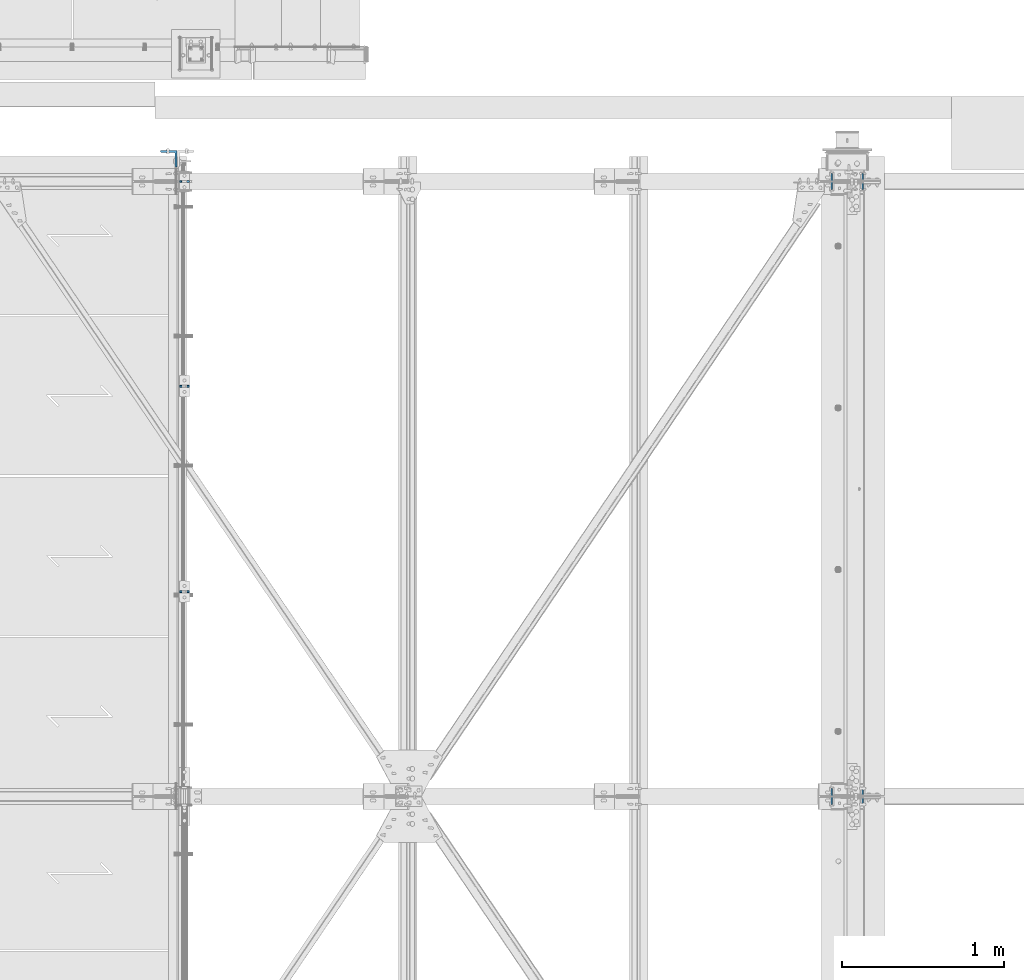
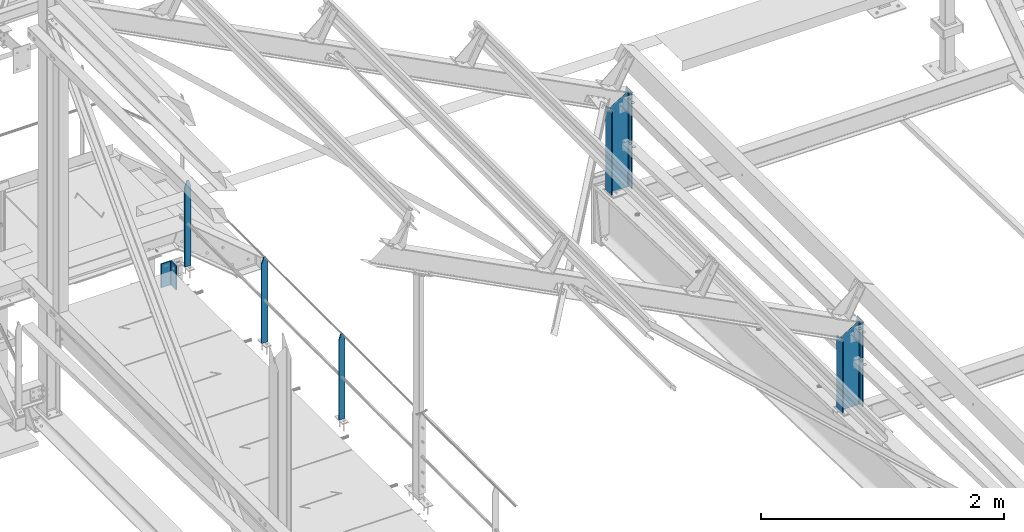
# One storey, part 33 of 496: 6 columns, 4 elements without a shape of their own.
"""IFC2X3 building model written with IfcOpenShell, lengths in millimetres."""

from ifc_helpers import new_model, si_unit, frame, origin_with_axes, origin_2d_with_axis, place, context, subcontext, project, spatial, rectangle, i_section, l_section, extrude, clip, halfspace, material, type_object, element, aggregate, save


model = new_model("IFC2X3")

# Units and contexts
model_context = context("Model", 3, precision=1e-05, world=origin_with_axes())
body_context = subcontext(model_context, "Body", "Model", "MODEL_VIEW")
ifc_project = project(units=[si_unit("LENGTHUNIT", "METRE", prefix="MILLI"), si_unit("AREAUNIT", "SQUARE_METRE"), si_unit("VOLUMEUNIT", "CUBIC_METRE"), si_unit("MASSUNIT", "GRAM", prefix="KILO"), si_unit("TIMEUNIT", "SECOND"), si_unit("PLANEANGLEUNIT", "RADIAN"), si_unit("SOLIDANGLEUNIT", "STERADIAN"), si_unit("THERMODYNAMICTEMPERATUREUNIT", "DEGREE_CELSIUS"), si_unit("LUMINOUSINTENSITYUNIT", "LUMEN")], contexts=[model_context])

# Site, building, storey
site_placement = place(None, origin_with_axes())
site = spatial("IfcSite", under=ifc_project, at=site_placement, CompositionType="ELEMENT")
building_placement = place(site_placement, origin_with_axes())
building = spatial("IfcBuilding", under=site, at=building_placement, Name="Undefined", CompositionType="ELEMENT")
storey_placement = place(building_placement, origin_with_axes())
storey = spatial("IfcBuildingStorey", under=building, at=storey_placement, Name="Undefined", CompositionType="ELEMENT", Elevation=0.0)

# Assembly, columns
assembly_1_placement = place(storey_placement, origin_with_axes())
assembly_1 = element("IfcElementAssembly", 1, at=assembly_1_placement, inside=storey, Name="MAIN COURANTE", AssemblyPlace="NOTDEFINED", PredefinedType="NOTDEFINED")
ifc_material_1 = material(Name="Undefined/S235-E24")
column_type_1 = type_object("IfcColumnType", PredefinedType="NOTDEFINED")
column_1_placement = place(assembly_1_placement, frame((24783.9916087498, 15200.0000000319, 8249.99999828624), z_axis=(0.0, 0.0, 1.0), x_axis=(1.0, 0.0, 0.0)))
column_1 = element("IfcColumn", 2, at=column_1_placement, type_object=column_type_1, material=ifc_material_1, Name="MONTANT", context=body_context, shape_type="Clipping", body=[
    clip(clip(extrude(rectangle(XDim=10.0, YDim=60.0, at=origin_2d_with_axis()), frame((0.0, 0.0, 857.599997130677), z_axis=(0.0, 0.0, -1.0), x_axis=(0.0, 1.0, 0.0)), (0.0, 0.0, 1.0), 857.6), halfspace(frame((30.0000001657245, -5.000000004674, 797.599997170884), z_axis=(0.948683298050514, 0.0, 0.316227766016838), x_axis=(-0.316227766016838, 0.0, 0.948683298050514)), False)), halfspace(frame((-29.9999998342682, 4.99999999524351, 797.599997177174), z_axis=(-0.948683298050514, 0.0, 0.316227766016838), x_axis=(0.316227766016838, 0.0, 0.948683298050514)), False)),
])
column_2_placement = place(assembly_1_placement, frame((24783.9916067239, 12665.0034395729, 8250.00000011812), z_axis=(0.0, 0.0, 1.0), x_axis=(1.0, 0.0, 0.0)))
column_2 = element("IfcColumn", 3, at=column_2_placement, type_object=column_type_1, material=ifc_material_1, Name="MONTANT", context=body_context, shape_type="Clipping", body=[
    clip(clip(extrude(rectangle(XDim=10.0, YDim=60.0, at=origin_2d_with_axis()), frame((0.0, 0.0, 857.599997130677), z_axis=(0.0, 0.0, -1.0), x_axis=(0.0, 1.0, 0.0)), (0.0, 0.0, 1.0), 857.6), halfspace(frame((30.0000001657245, -5.000000004674, 797.599997170884), z_axis=(0.948683298050514, 0.0, 0.316227766016838), x_axis=(-0.316227766016838, 0.0, 0.948683298050514)), False)), halfspace(frame((-29.9999998342682, 4.99999999524351, 797.599997177174), z_axis=(-0.948683298050514, 0.0, 0.316227766016838), x_axis=(0.316227766016838, 0.0, 0.948683298050514)), False)),
])
column_3_placement = place(assembly_1_placement, frame((24783.9916077785, 13935.0034395729, 8249.99999924743), z_axis=(0.0, 0.0, 1.0), x_axis=(1.0, 0.0, 0.0)))
column_3 = element("IfcColumn", 4, at=column_3_placement, type_object=column_type_1, material=ifc_material_1, Name="MONTANT", context=body_context, shape_type="Clipping", body=[
    clip(clip(extrude(rectangle(XDim=10.0, YDim=60.0, at=origin_2d_with_axis()), frame((0.0, 0.0, 857.599997130677), z_axis=(0.0, 0.0, -1.0), x_axis=(0.0, 1.0, 0.0)), (0.0, 0.0, 1.0), 857.6), halfspace(frame((30.0000001657245, -5.000000004674, 797.599997170884), z_axis=(0.948683298050514, 0.0, 0.316227766016838), x_axis=(-0.316227766016838, 0.0, 0.948683298050514)), False)), halfspace(frame((-29.9999998342682, 4.99999999524351, 797.599997177174), z_axis=(-0.948683298050514, 0.0, 0.316227766016838), x_axis=(0.316227766016838, 0.0, 0.948683298050514)), False)),
])
aggregate(assembly_1, [column_1, column_2, column_3])

# Assembly, column
assembly_2_placement = place(storey_placement, origin_with_axes())
assembly_2 = element("IfcElementAssembly", 5, at=assembly_2_placement, inside=storey, AssemblyPlace="NOTDEFINED", PredefinedType="NOTDEFINED")
column_type_2 = type_object("IfcColumnType", PredefinedType="NOTDEFINED")
column_4_placement = place(assembly_2_placement, frame((24686.491600645, 15339.9999999094, 7970.00437164953), z_axis=(0.0, 0.0, 1.0), x_axis=(-1.0, 0.0, 0.0)))
column_4 = element("IfcColumn", 6, at=column_4_placement, type_object=column_type_2, material=ifc_material_1, context=body_context, shape_type="SweptSolid", body=[
    extrude(l_section(Depth=100.0, Width=100.0, Thickness=10.0, FilletRadius=12.0, EdgeRadius=6.0, at=origin_2d_with_axis()), frame((0.0, 0.0, 239.999999999999), z_axis=(0.0, 0.0, -1.0), x_axis=(0.0, 1.0, 0.0)), (0.0, 0.0, 1.0), 240.0),
])
aggregate(assembly_2, [column_4])

assembly_3_placement = place(storey_placement, origin_with_axes())
assembly_3 = element("IfcElementAssembly", 7, at=assembly_3_placement, inside=storey, Name="TRAVERSE SHED", AssemblyPlace="NOTDEFINED", PredefinedType="NOTDEFINED")
ifc_material_2 = material(Name="Undefined/S275-E28")
column_type_3 = type_object("IfcColumnType", Name="IPE200", PredefinedType="NOTDEFINED")
column_5_placement = place(assembly_3_placement, frame((28880.0, 15200.0, 7572.32075715959), z_axis=(0.0, 0.0, 1.0), x_axis=(-1.0, 0.0, 0.0)))
column_5 = element("IfcColumn", 8, at=column_5_placement, type_object=column_type_3, material=ifc_material_2, Name="TRAVERSE SHED", ObjectType="IPE200", context=body_context, shape_type="Clipping", body=[
    clip(clip(extrude(i_section(OverallWidth=100.0, OverallDepth=200.0, WebThickness=5.599999905, FlangeThickness=8.5, FilletRadius=12.0, at=origin_2d_with_axis()), frame((0.0, 0.0, 979.874368170381), z_axis=(0.0, 0.0, -1.0), x_axis=(0.0, 1.0, 0.0)), (0.0, 0.0, 1.0), 1032.87), halfspace(frame((-100.000000738131, 11400.0, 977.679244306995), z_axis=(0.519570377152939, 0.0, 0.854427658251506), x_axis=(0.0, 1.0, 0.0)), False)), halfspace(frame((0.0, -61.6670185934854, 8.06698960952508), z_axis=(0.0, 0.031410477145298, -0.999506569225788), x_axis=(1.0, 0.0, 0.0)), False)),
])
aggregate(assembly_3, [column_5])

assembly_4_placement = place(storey_placement, origin_with_axes())
assembly_4 = element("IfcElementAssembly", 9, at=assembly_4_placement, inside=storey, Name="TRAVERSE SHED", AssemblyPlace="NOTDEFINED", PredefinedType="NOTDEFINED")
column_6_placement = place(assembly_4_placement, frame((28880.0, 11400.0, 7691.74056786936), z_axis=(0.0, 0.0, 1.0), x_axis=(-1.0, 0.0, 0.0)))
column_6 = element("IfcColumn", 10, at=column_6_placement, type_object=column_type_3, material=ifc_material_2, Name="TRAVERSE SHED", ObjectType="IPE200", context=body_context, shape_type="Clipping", body=[
    clip(clip(extrude(i_section(OverallWidth=100.0, OverallDepth=200.0, WebThickness=5.599999905, FlangeThickness=8.5, FilletRadius=12.0, at=origin_2d_with_axis()), frame((0.0, 0.0, 860.454557460618), z_axis=(0.0, 0.0, -1.0), x_axis=(0.0, 1.0, 0.0)), (0.0, 0.0, 1.0), 913.45), halfspace(frame((-100.000000738131, 7600.0, 858.259433597233), z_axis=(0.519570377152939, 0.0, 0.854427658251506), x_axis=(0.0, 1.0, 0.0)), False)), halfspace(frame((0.0, -22.8324402339822, 9.28788433863247), z_axis=(0.0, 0.031410477145298, -0.999506569225788), x_axis=(1.0, 0.0, 0.0)), False)),
])
aggregate(assembly_4, [column_6])

save(model, "model.ifc")
